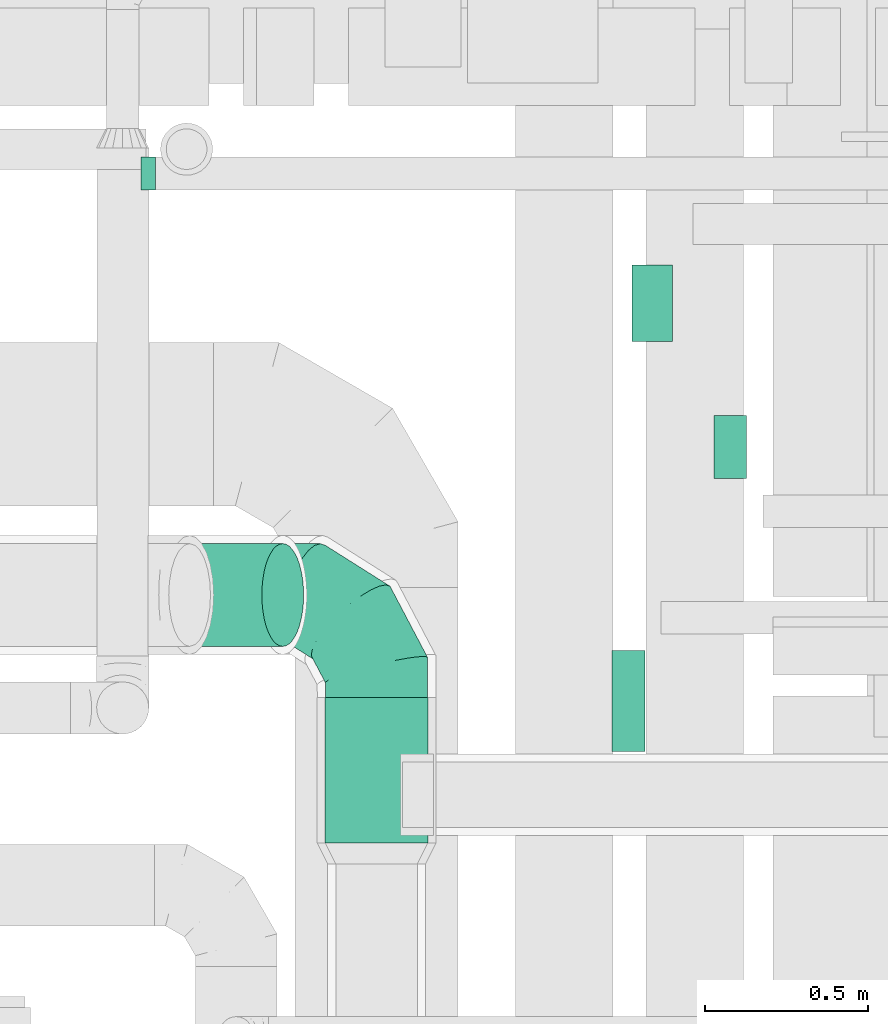
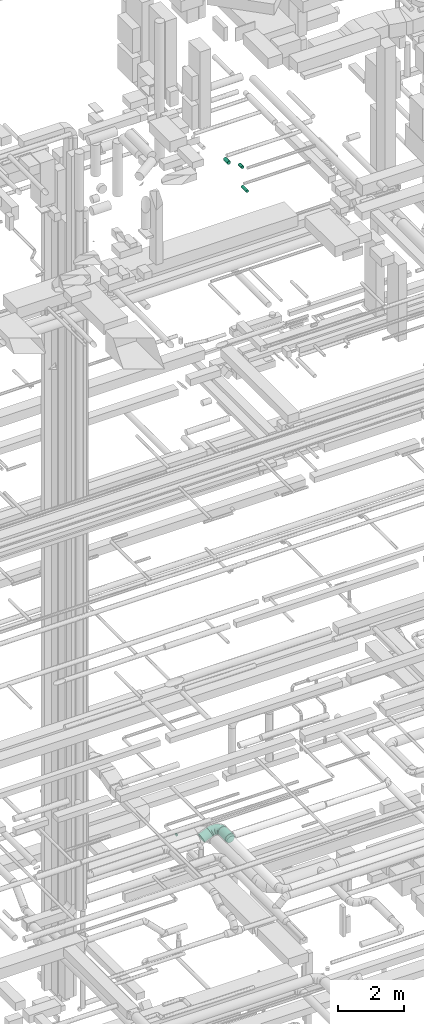
# One storey, part 149 of 337: 5 flow segments, 2 flow fittings.
"""IFC2X3 building model written with IfcOpenShell, lengths in millimetres."""

import ifcopenshell
import ifcopenshell.guid

model = None  # the IFC model being written
_history = None  # IfcOwnerHistory: only IFC2X3 demands one
_inside = {}  # id of a spatial element -> (the spatial element, [elements in it])
_under = {}  # id of a project, library or spatial element -> (it, [spatial elements below it])
_declared = {}  # id of a project -> (the project, [libraries it declares])
_typed = {}  # id of a type object -> (the type object, [elements of that type])
_made_of = {}  # id of a material, layer set ... -> (it, [elements and type objects made of it])


def new_model(schema):
    """Start an empty IFC model of exactly this schema.

    Asked for "IFC4X3", IfcOpenShell would pick the latest addendum, in which some entities
    have other attributes; the version numbers below select the first issue.
    IFC2X3 requires an IfcOwnerHistory on every rooted entity: one is made here for all.
    """
    global model, _history
    if schema == "IFC4X3":
        model = ifcopenshell.file(schema_version=(4, 3, 0, 0))
    else:
        model = ifcopenshell.file(schema=schema)
    _inside.clear()
    _under.clear()
    _declared.clear()
    _typed.clear()
    _made_of.clear()
    _history = None
    if model.schema == "IFC2X3":
        org = make("IfcOrganization", Name="unknown")
        user = make(
            "IfcPersonAndOrganization",
            ThePerson=make("IfcPerson", FamilyName="unknown"),
            TheOrganization=org,
        )
        app = make(
            "IfcApplication",
            ApplicationDeveloper=org,
            Version="unknown",
            ApplicationFullName="unknown",
            ApplicationIdentifier="unknown",
        )
        _history = make(
            "IfcOwnerHistory",
            OwningUser=user,
            OwningApplication=app,
            ChangeAction="ADDED",
            CreationDate=0,
        )
    return model


def make(cls, **values):
    """One entity of the class cls with the attributes given. An attribute that is None is left unset."""
    return model.create_entity(
        cls, **{name: value for name, value in values.items() if value is not None}
    )


def entity(cls, *values):
    """Any entity or typed value of the class cls, its attributes in the order of the schema. None: left unset."""
    e = model.create_entity(cls)
    for i, value in enumerate(values):
        if value is not None:
            e[i] = value
    return e


def rooted(cls, **values):
    """An entity with a GlobalId (a new one), such as an element, a storey or a relation."""
    return make(cls, GlobalId=ifcopenshell.guid.new(), OwnerHistory=_history, **values)


def si_unit(unit_type, name, prefix=None):
    """IfcSIUnit, for example si_unit("LENGTHUNIT", "METRE", prefix="MILLI")."""
    return make("IfcSIUnit", UnitType=unit_type, Prefix=prefix, Name=name)


def converted_unit(unit_type, name, factor, base, dimensions=None, offset=None):
    """IfcConversionBasedUnit, such as the inch: factor (a typed value) times the base unit."""
    return make(
        "IfcConversionBasedUnit"
        if offset is None
        else "IfcConversionBasedUnitWithOffset",
        ConversionOffset=offset,
        Dimensions=None
        if dimensions is None
        else entity("IfcDimensionalExponents", *dimensions),
        UnitType=unit_type,
        Name=name,
        ConversionFactor=make(
            "IfcMeasureWithUnit", ValueComponent=factor, UnitComponent=base
        ),
    )


def derived_unit(unit_type, elements):
    """IfcDerivedUnit: a product of units, each with its exponent."""
    return make(
        "IfcDerivedUnit",
        Elements=[
            make("IfcDerivedUnitElement", Unit=unit, Exponent=power)
            for unit, power in elements
        ],
        UnitType=unit_type,
    )


def assignment(units):
    """IfcUnitAssignment: the units of a project."""
    return None if units is None else make("IfcUnitAssignment", Units=units)


def point(xyz):
    """IfcCartesianPoint."""
    return None if xyz is None else make("IfcCartesianPoint", Coordinates=xyz)


def direction(xyz):
    """IfcDirection."""
    return None if xyz is None else make("IfcDirection", DirectionRatios=xyz)


def frame(location, z_axis=None, x_axis=None):
    """IfcAxis2Placement3D, a coordinate frame: its origin and axes. An axis left out is left unset."""
    return make(
        "IfcAxis2Placement3D",
        Location=point(location),
        Axis=direction(z_axis),
        RefDirection=direction(x_axis),
    )


def frame_2d(location, x_axis=None):
    """IfcAxis2Placement2D, a coordinate frame in the plane: its origin and x axis."""
    return make(
        "IfcAxis2Placement2D", Location=point(location), RefDirection=direction(x_axis)
    )


def origin():
    """The frame at (0, 0, 0) with its axes left unset."""
    return frame((0.0, 0.0, 0.0))


def origin_2d_with_axis():
    """The frame at (0, 0) in the plane with the x axis (1, 0) written out."""
    return frame_2d((0.0, 0.0), x_axis=(1.0, 0.0))


def place(relative_to, where):
    """IfcLocalPlacement: puts the frame where relative to a parent placement (None: the world)."""
    return make(
        "IfcLocalPlacement", PlacementRelTo=relative_to, RelativePlacement=where
    )


def context(
    kind, dimensions, precision=None, world=None, true_north=None, identifier=None
):
    """IfcGeometricRepresentationContext, for example the 3D "Model" context."""
    return make(
        "IfcGeometricRepresentationContext",
        ContextIdentifier=identifier,
        ContextType=kind,
        CoordinateSpaceDimension=dimensions,
        Precision=precision,
        WorldCoordinateSystem=world,
        TrueNorth=true_north,
    )


def subcontext(parent, identifier, kind, view, scale=None):
    """IfcGeometricRepresentationSubContext, for example "Body" below "Model"."""
    return make(
        "IfcGeometricRepresentationSubContext",
        ContextIdentifier=identifier,
        ContextType=kind,
        ParentContext=parent,
        TargetScale=scale,
        TargetView=view,
    )


def project(units=None, contexts=None):
    """IfcProject with its units and contexts."""
    return rooted(
        "IfcProject",
        Name="project",
        RepresentationContexts=contexts,
        UnitsInContext=assignment(units),
    )


def spatial(cls, under=None, at=None, **own):
    """A site, building, storey or space (cls), placed at a placement, below another one or the project."""
    s = rooted(cls, ObjectPlacement=at, **own)
    if under is not None:
        _under.setdefault(under.id(), (under, []))[1].append(s)
    return s


def profile(cls, at=None, kind="AREA", **sizes):
    """A parametric profile (cls). Its sizes go by their IFC names, for example OverallWidth=200.0."""
    return make(cls, ProfileType=kind, Position=at, **sizes)


def circle(**sizes):
    """IfcCircleProfileDef."""
    return profile("IfcCircleProfileDef", **sizes)


def extrude(swept, where, along, depth):
    """IfcExtrudedAreaSolid: the profile swept, set in the frame where, extruded along a direction by depth."""
    return make(
        "IfcExtrudedAreaSolid",
        SweptArea=swept,
        Position=where,
        ExtrudedDirection=direction(along),
        Depth=depth,
    )


def faces_of(points, faces, orient=None, outer=None):
    """IfcFace entities. A face is a list of loops; a loop is a list of indices into points, from 0.

    orient and outer hold one flag for each loop. By default every Orientation is true, the
    first loop of a face is its IfcFaceOuterBound and the others are IfcFaceBound.
    """
    made = []
    for i, loops in enumerate(faces):
        bounds = []
        for j, loop in enumerate(loops):
            is_outer = j == 0 if outer is None else outer[i][j]
            bounds.append(
                make(
                    "IfcFaceOuterBound" if is_outer else "IfcFaceBound",
                    Bound=make("IfcPolyLoop", Polygon=[points[k] for k in loop]),
                    Orientation=True if orient is None else orient[i][j],
                )
            )
        made.append(make("IfcFace", Bounds=bounds))
    return made


def faceted_brep(points, faces, orient=None, outer=None, voids=None):
    """IfcFacetedBrep: a solid bounded by flat faces; with voids (closed shells), ...WithVoids."""
    shared = [point(p) for p in points]
    hull = make("IfcClosedShell", CfsFaces=faces_of(shared, faces, orient, outer))
    if voids is None:
        return make("IfcFacetedBrep", Outer=hull)
    return make(
        "IfcFacetedBrepWithVoids",
        Outer=hull,
        Voids=[
            make(cls, CfsFaces=faces_of(shared, fs, o, b)) for cls, fs, o, b in voids
        ],
    )


def shape(context_of_items, identifier, shape_type, items):
    """IfcShapeRepresentation: the items that make up one representation, for example the "Body"."""
    return make(
        "IfcShapeRepresentation",
        ContextOfItems=context_of_items,
        RepresentationIdentifier=identifier,
        RepresentationType=shape_type,
        Items=items,
    )


def source(mapping_origin, context_of_items, identifier, shape_type, items):
    """IfcRepresentationMap: a shape defined once, which mapped items show again and again."""
    return make(
        "IfcRepresentationMap",
        MappingOrigin=mapping_origin,
        MappedRepresentation=shape(context_of_items, identifier, shape_type, items),
    )


def transform(
    local_origin,
    x_axis=None,
    y_axis=None,
    z_axis=None,
    scale=None,
    scale2=None,
    scale3=None,
    uniform=True,
):
    """IfcCartesianTransformationOperator3D, or its non-uniform kind. x_axis, y_axis, z_axis: its Axis1, 2, 3."""
    if uniform:
        return make(
            "IfcCartesianTransformationOperator3D",
            Axis1=direction(x_axis),
            Axis2=direction(y_axis),
            LocalOrigin=point(local_origin),
            Scale=scale,
            Axis3=direction(z_axis),
        )
    return make(
        "IfcCartesianTransformationOperator3DnonUniform",
        Axis1=direction(x_axis),
        Axis2=direction(y_axis),
        LocalOrigin=point(local_origin),
        Scale=scale,
        Axis3=direction(z_axis),
        Scale2=scale2,
        Scale3=scale3,
    )


def mapped(mapping_source, mapping_target):
    """IfcMappedItem: shows the shape of a source again, moved by a transform."""
    return make(
        "IfcMappedItem", MappingSource=mapping_source, MappingTarget=mapping_target
    )


def material(Name=None, Category=None):
    """IfcMaterial."""
    return make("IfcMaterial", Name=Name, Category=Category)


def made_of(thing, what):
    """Note that an element or type object is made of a material, layer set ...; save() writes the relation."""
    if what is not None:
        _made_of.setdefault(what.id(), (what, []))[1].append(thing)
    return thing


def type_object(cls, material=None, **own):
    """A type object (cls), such as IfcWallType, which elements share."""
    return made_of(rooted(cls, **own), material)


def type_shapes(of_type, sources):
    """Give a type object the sources (RepresentationMaps) that its elements show as mapped items."""
    of_type.RepresentationMaps = sources


def element(
    cls,
    number,
    at=None,
    inside=None,
    cuts=None,
    type_object=None,
    material=None,
    context=None,
    identifier="Body",
    shape_type=None,
    held_by="IfcProductDefinitionShape",
    body=None,
    shapes=None,
    **own,
):
    """One element of the class cls, such as IfcWall. Its Tag is "e" and its number.

    at: its placement. inside: the storey or other place that contains it. cuts: it is an
    opening in that element (IfcRelVoidsElement). A single representation is given by context,
    identifier, shape_type and body (its items); several are given by shapes. held_by: the class
    of the entity that holds the representations. save() writes the other relations.
    """
    e = rooted(cls, Tag="e%d" % number, ObjectPlacement=at, **own)
    if body is not None:
        shapes = [shape(context, identifier, shape_type, body)]
    if shapes is not None:
        e.Representation = make(held_by, Representations=shapes)
    if inside is not None:
        _inside.setdefault(inside.id(), (inside, []))[1].append(e)
    if cuts is not None:
        rooted(
            "IfcRelVoidsElement", RelatingBuildingElement=cuts, RelatedOpeningElement=e
        )
    if type_object is not None:
        _typed.setdefault(type_object.id(), (type_object, []))[1].append(e)
    return made_of(e, material)


def aggregate(whole, parts):
    """IfcRelAggregates: a whole, such as a stair, and the parts it consists of."""
    return rooted("IfcRelAggregates", RelatingObject=whole, RelatedObjects=parts)


def save(model, path):
    """Write the relations noted so far, then the file.

    IfcRelAggregates (storeys below a building ...), IfcRelContainedInSpatialStructure (elements
    in a storey), IfcRelDefinesByType, IfcRelAssociatesMaterial and IfcRelDeclares: one each for
    every whole, place, type object, material and project.
    """
    for whole, parts in _under.values():
        aggregate(whole, parts)
    for where, things in _inside.values():
        rooted(
            "IfcRelContainedInSpatialStructure",
            RelatedElements=things,
            RelatingStructure=where,
        )
    for kind, things in _typed.values():
        rooted("IfcRelDefinesByType", RelatedObjects=things, RelatingType=kind)
    for what, things in _made_of.values():
        rooted("IfcRelAssociatesMaterial", RelatedObjects=things, RelatingMaterial=what)
    for by, libraries in _declared.values():
        rooted("IfcRelDeclares", RelatingContext=by, RelatedDefinitions=libraries)
    model.write(path)


model = new_model("IFC2X3")

# Units and contexts
model_context = context("Model", 3, precision=0.01, world=origin(), true_north=direction((6.12303176911189e-17, 1.0)))
body_context = subcontext(model_context, "Body", "Model", "MODEL_VIEW")
ifc_project = project(units=[si_unit("LENGTHUNIT", "METRE", prefix="MILLI"), si_unit("AREAUNIT", "SQUARE_METRE"), si_unit("VOLUMEUNIT", "CUBIC_METRE"), converted_unit("PLANEANGLEUNIT", "DEGREE", entity("IfcRatioMeasure", 0.0174532925199433), si_unit("PLANEANGLEUNIT", "RADIAN"), dimensions=[0, 0, 0, 0, 0, 0, 0]), si_unit("MASSUNIT", "GRAM", prefix="KILO"), derived_unit("MASSDENSITYUNIT", [(si_unit("MASSUNIT", "GRAM", prefix="KILO"), 1), (si_unit("LENGTHUNIT", "METRE"), -3)]), derived_unit("MOMENTOFINERTIAUNIT", [(si_unit("LENGTHUNIT", "METRE"), 4)]), si_unit("TIMEUNIT", "SECOND"), si_unit("FREQUENCYUNIT", "HERTZ"), si_unit("THERMODYNAMICTEMPERATUREUNIT", "DEGREE_CELSIUS"), derived_unit("THERMALTRANSMITTANCEUNIT", [(si_unit("MASSUNIT", "GRAM", prefix="KILO"), 1), (si_unit("THERMODYNAMICTEMPERATUREUNIT", "KELVIN"), -1), (si_unit("TIMEUNIT", "SECOND"), -3)]), derived_unit("VOLUMETRICFLOWRATEUNIT", [(si_unit("LENGTHUNIT", "METRE"), 3), (si_unit("TIMEUNIT", "SECOND"), -1)]), derived_unit("MASSFLOWRATEUNIT", [(si_unit("MASSUNIT", "GRAM", prefix="KILO"), 1), (si_unit("TIMEUNIT", "SECOND"), -1)]), derived_unit("ROTATIONALFREQUENCYUNIT", [(si_unit("TIMEUNIT", "SECOND"), -1)]), si_unit("ELECTRICCURRENTUNIT", "AMPERE"), si_unit("ELECTRICVOLTAGEUNIT", "VOLT"), si_unit("POWERUNIT", "WATT"), si_unit("FORCEUNIT", "NEWTON", prefix="KILO"), si_unit("ILLUMINANCEUNIT", "LUX"), si_unit("LUMINOUSFLUXUNIT", "LUMEN"), si_unit("LUMINOUSINTENSITYUNIT", "CANDELA"), derived_unit("USERDEFINED", [(si_unit("MASSUNIT", "GRAM", prefix="KILO"), -1), (si_unit("LENGTHUNIT", "METRE"), -2), (si_unit("TIMEUNIT", "SECOND"), 3), (si_unit("LUMINOUSFLUXUNIT", "LUMEN"), 1)]), derived_unit("LINEARVELOCITYUNIT", [(si_unit("LENGTHUNIT", "METRE"), 1), (si_unit("TIMEUNIT", "SECOND"), -1)]), si_unit("PRESSUREUNIT", "PASCAL"), derived_unit("USERDEFINED", [(si_unit("LENGTHUNIT", "METRE"), -2), (si_unit("MASSUNIT", "GRAM", prefix="KILO"), 1), (si_unit("TIMEUNIT", "SECOND"), -2)]), derived_unit("LINEARFORCEUNIT", [(si_unit("MASSUNIT", "GRAM", prefix="KILO"), 1), (si_unit("LENGTHUNIT", "METRE"), 1), (si_unit("TIMEUNIT", "SECOND"), -2), (si_unit("LENGTHUNIT", "METRE"), -1)]), derived_unit("PLANARFORCEUNIT", [(si_unit("MASSUNIT", "GRAM", prefix="KILO"), 1), (si_unit("LENGTHUNIT", "METRE"), 1), (si_unit("TIMEUNIT", "SECOND"), -2), (si_unit("LENGTHUNIT", "METRE"), -2)])], contexts=[model_context])

# Site, building, storey
site_placement = place(None, origin())
site = spatial("IfcSite", under=ifc_project, at=site_placement, CompositionType="ELEMENT")
building_placement = place(site_placement, origin())
building = spatial("IfcBuilding", under=site, at=building_placement, CompositionType="ELEMENT")
storey_placement = place(building_placement, origin())
storey = spatial("IfcBuildingStorey", under=building, at=storey_placement, CompositionType="ELEMENT", Elevation=0.0)

# Flow segments
duct_segment_type = type_object("IfcDuctSegmentType", PredefinedType="NOTDEFINED")
flow_segment_1_placement = place(storey_placement, frame((36585.46, 11764.99, 3423.4)))
element("IfcFlowSegment", 1, at=flow_segment_1_placement, inside=storey, type_object=duct_segment_type, context=body_context, shape_type="SweptSolid", body=[
    extrude(circle(Radius=157.5, at=origin_2d_with_axis()), frame((159.1, 0.0, 159.1), z_axis=(0.0, 1.0, 0.0), x_axis=(-1.0, 0.0, 0.0)), (0.0, 0.0, 1.0), 445.00000000002),
])
flow_segment_2_placement = place(storey_placement, frame((37465.61, 12045.11, 27148.4)))
element("IfcFlowSegment", 2, at=flow_segment_2_placement, inside=storey, type_object=duct_segment_type, context=body_context, shape_type="SweptSolid", body=[
    extrude(circle(Radius=50.0, at=origin_2d_with_axis()), frame((51.6, 0.0, 51.6), z_axis=(0.0, 1.0, 0.0), x_axis=(-1.0, 0.0, 0.0)), (0.0, 0.0, 1.0), 310.000000000025),
])
flow_segment_3_placement = place(storey_placement, frame((37525.93, 13302.52, 27410.9)))
element("IfcFlowSegment", 3, at=flow_segment_3_placement, inside=storey, type_object=duct_segment_type, context=body_context, shape_type="SweptSolid", body=[
    extrude(circle(Radius=62.5, at=origin_2d_with_axis()), frame((64.1, 0.0, 64.1), z_axis=(0.0, 1.0, 0.0), x_axis=(-1.0, 0.0, 0.0)), (0.0, 0.0, 1.0), 234.999336148994),
])
flow_segment_4_placement = place(storey_placement, frame((37777.3, 12881.82, 27423.4)))
element("IfcFlowSegment", 4, at=flow_segment_4_placement, inside=storey, type_object=duct_segment_type, context=body_context, shape_type="SweptSolid", body=[
    extrude(circle(Radius=50.0, at=origin_2d_with_axis()), frame((51.6, 0.0, 51.6), z_axis=(0.0, 1.0, 0.0), x_axis=(1.0, 0.0, 0.0)), (0.0, 0.0, 1.0), 194.375000000006),
])
flow_segment_5_placement = place(storey_placement, frame((36105.56, 12365.89, 3181.75)))
element("IfcFlowSegment", 5, at=flow_segment_5_placement, inside=storey, type_object=duct_segment_type, context=body_context, shape_type="SweptSolid", body=[
    extrude(circle(Radius=157.5, at=origin_2d_with_axis()), frame((65.66, 159.1, 145.48), z_axis=(0.913545457642601, 0.0, 0.406736643075801), x_axis=(0.0, 1.0, 0.0)), (0.0, 0.0, 1.0), 312.597300373771),
])

# Flow fittings
ifc_material = material()
duct_fitting_type_1 = type_object("IfcDuctFittingType", PredefinedType="NOTDEFINED", material=ifc_material)
shared_shape_1 = source(origin(), body_context, "Body", "Brep", [
    faceted_brep([(20.0, 12.94, -48.3), (20.0, 25.0, -43.3), (20.0, 35.36, -35.36), (20.0, 43.3, -25.0), (20.0, 48.3, -12.94), (20.0, 50.0, 0.0), (20.0, 48.3, 12.94), (20.0, 43.3, 25.0), (20.0, 35.36, 35.36), (20.0, 25.0, 43.3), (20.0, 12.94, 48.3), (20.0, 0.0, 50.0), (20.0, -12.94, 48.3), (20.0, -25.0, 43.3), (20.0, -35.36, 35.36), (20.0, -43.3, 25.0), (20.0, -48.3, 12.94), (20.0, -50.0, 0.0), (20.0, -48.3, -12.94), (20.0, -43.3, -25.0), (20.0, -35.36, -35.36), (20.0, -25.0, -43.3), (20.0, -12.94, -48.3), (20.0, 0.0, -50.0), (0.0, 0.0, 50.0), (0.0, 12.94, 48.3), (-23.65, 12.94, 48.3), (-23.65, 0.0, 50.0), (0.0, 25.0, 43.3), (-23.65, 25.0, 43.3), (0.0, 35.36, 35.36), (-23.65, 35.36, 35.36), (0.0, 43.3, 25.0), (0.0, 48.3, 12.94), (-23.65, 48.3, 12.94), (-23.65, 43.3, 25.0), (0.0, 50.0, 0.0), (-23.65, 50.0, 0.0), (0.0, 48.3, -12.94), (-23.65, 48.3, -12.94), (0.0, 43.3, -25.0), (-23.65, 43.3, -25.0), (0.0, 35.36, -35.36), (-23.65, 35.36, -35.36), (0.0, 25.0, -43.3), (0.0, 12.94, -48.3), (-23.65, 12.94, -48.3), (-23.65, 25.0, -43.3), (0.0, 0.0, -50.0), (-23.65, 0.0, -50.0), (0.0, -12.94, -48.3), (-23.65, -12.94, -48.3), (0.0, -25.0, -43.3), (-23.65, -25.0, -43.3), (0.0, -35.36, -35.36), (-23.65, -35.36, -35.36), (0.0, -43.3, -25.0), (0.0, -48.3, -12.94), (-23.65, -48.3, -12.94), (-23.65, -43.3, -25.0), (0.0, -50.0, 0.0), (-23.65, -50.0, 0.0), (0.0, -48.3, 12.94), (-23.65, -48.3, 12.94), (0.0, -43.3, 25.0), (-23.65, -43.3, 25.0), (0.0, -35.36, 35.36), (-23.65, -35.36, 35.36), (0.0, -25.0, 43.3), (0.0, -12.94, 48.3), (-23.65, -12.94, 48.3), (-23.65, -25.0, 43.3)], [[[0, 1, 2, 3, 4, 5, 6, 7, 8, 9, 10, 11, 12, 13, 14, 15, 16, 17, 18, 19, 20, 21, 22, 23]], [[24, 11, 10, 25, 26, 27]], [[25, 10, 9, 28, 29, 26]], [[28, 9, 8, 30, 31, 29]], [[32, 7, 6, 33, 34, 35]], [[33, 6, 5, 36, 37, 34]], [[30, 8, 7, 32, 35, 31]], [[36, 5, 4, 38, 39, 37]], [[38, 4, 3, 40, 41, 39]], [[40, 3, 2, 42, 43, 41]], [[44, 1, 0, 45, 46, 47]], [[45, 0, 23, 48, 49, 46]], [[42, 2, 1, 44, 47, 43]], [[48, 23, 22, 50, 51, 49]], [[50, 22, 21, 52, 53, 51]], [[52, 21, 20, 54, 55, 53]], [[56, 19, 18, 57, 58, 59]], [[57, 18, 17, 60, 61, 58]], [[54, 20, 19, 56, 59, 55]], [[60, 17, 16, 62, 63, 61]], [[62, 16, 15, 64, 65, 63]], [[64, 15, 14, 66, 67, 65]], [[68, 13, 12, 69, 70, 71]], [[69, 12, 11, 24, 27, 70]], [[66, 14, 13, 68, 71, 67]], [[49, 51, 53, 55, 59, 58, 61, 63, 65, 67, 71, 70, 27, 26, 29, 31, 35, 34, 37, 39, 41, 43, 47, 46]]]),
])
type_shapes(duct_fitting_type_1, [shared_shape_1])
flow_fitting_1_placement = place(storey_placement, frame((36046.08, 13817.68, 2720.0), z_axis=(0.0, 0.0, -1.0), x_axis=(1.0, 0.0, 0.0)))
element("IfcFlowFitting", 6, at=flow_fitting_1_placement, inside=storey, type_object=duct_fitting_type_1, material=ifc_material, context=body_context, shape_type="MappedRepresentation", body=[
    mapped(shared_shape_1, transform((0.0, 0.0, 0.0), scale=1.0)),
])
duct_fitting_type_2 = type_object("IfcDuctFittingType", PredefinedType="NOTDEFINED", material=ifc_material)
shared_shape_2 = source(origin(), body_context, "Body", "Brep", [
    faceted_brep([(-315.0, 0.0, -157.5), (-315.0, -40.76, -152.13), (-315.0, -78.75, -136.4), (-315.0, -111.37, -111.37), (-315.0, -136.4, -78.75), (-315.0, -152.13, -40.76), (-315.0, -157.5, 0.0), (-315.0, -152.13, 40.76), (-315.0, -136.4, 78.75), (-315.0, -111.37, 111.37), (-315.0, -78.75, 136.4), (-315.0, -40.76, 152.13), (-315.0, 0.0, 157.5), (-315.0, 40.76, 152.13), (-315.0, 78.75, 136.4), (-315.0, 111.37, 111.37), (-315.0, 136.4, 78.75), (-315.0, 152.13, 40.76), (-315.0, 157.5, 0.0), (-315.0, 152.13, -40.76), (-315.0, 136.4, -78.75), (-315.0, 111.37, -111.37), (-315.0, 78.75, -136.4), (-315.0, 40.76, -152.13), (-241.52, 40.76, 152.13), (-251.7, 78.75, 136.4), (-230.6, 0.0, 157.5), (-260.44, 111.37, 111.37), (-271.36, 152.13, 40.76), (-272.8, 157.5, 0.0), (-267.14, 136.4, 78.75), (-267.14, 136.4, -78.75), (-260.44, 111.37, -111.37), (-271.36, 152.13, -40.76), (-241.52, 40.76, -152.13), (-230.6, 0.0, -157.5), (-251.7, 78.75, -136.4), (-219.67, -40.76, -152.13), (-209.5, -78.75, -136.4), (-200.75, -111.37, -111.37), (-194.05, -136.4, -78.75), (-189.83, -152.13, -40.76), (-188.39, -157.5, 0.0), (-189.83, -152.13, 40.76), (-194.05, -136.4, 78.75), (-200.75, -111.37, 111.37), (-209.5, -78.75, 136.4), (-219.67, -40.76, 152.13), (-114.25, 114.25, 152.13), (-142.05, 142.05, 136.4), (-84.4, 84.4, 157.5), (-165.93, 165.93, 111.37), (-184.25, 184.25, 78.75), (-195.77, 195.77, 40.76), (-199.7, 199.7, 0.0), (-195.77, 195.77, -40.76), (-184.25, 184.25, -78.75), (-165.93, 165.93, -111.37), (-114.25, 114.25, -152.13), (-84.4, 84.4, -157.5), (-142.05, 142.05, -136.4), (-54.56, 54.56, -152.13), (-26.75, 26.75, -136.4), (-2.88, 2.88, -111.37), (15.45, -15.45, -78.75), (26.97, -26.97, -40.76), (30.89, -30.89, 0.0), (26.97, -26.97, 40.76), (15.45, -15.45, 78.75), (-2.88, 2.88, 111.37), (-26.75, 26.75, 136.4), (-54.56, 54.56, 152.13), (-40.76, 241.52, 152.13), (-78.75, 251.7, 136.4), (0.0, 230.6, 157.5), (-111.37, 260.44, 111.37), (-136.4, 267.14, 78.75), (-152.13, 271.36, 40.76), (-157.5, 272.8, 0.0), (-152.13, 271.36, -40.76), (-136.4, 267.14, -78.75), (-111.37, 260.44, -111.37), (-40.76, 241.52, -152.13), (0.0, 230.6, -157.5), (-78.75, 251.7, -136.4), (40.76, 219.67, -152.13), (78.75, 209.5, -136.4), (111.37, 200.75, -111.37), (136.4, 194.05, -78.75), (152.13, 189.83, -40.76), (157.5, 188.39, 0.0), (152.13, 189.83, 40.76), (136.4, 194.05, 78.75), (111.37, 200.75, 111.37), (78.75, 209.5, 136.4), (40.76, 219.67, 152.13), (-40.76, 315.0, -152.13), (-78.75, 315.0, -136.4), (-111.37, 315.0, -111.37), (-136.4, 315.0, -78.75), (-152.13, 315.0, -40.76), (-157.5, 315.0, 0.0), (-152.13, 315.0, 40.76), (-136.4, 315.0, 78.75), (-111.37, 315.0, 111.37), (-78.75, 315.0, 136.4), (-40.76, 315.0, 152.13), (0.0, 315.0, 157.5), (40.76, 315.0, 152.13), (78.75, 315.0, 136.4), (111.37, 315.0, 111.37), (136.4, 315.0, 78.75), (152.13, 315.0, 40.76), (157.5, 315.0, 0.0), (152.13, 315.0, -40.76), (136.4, 315.0, -78.75), (111.37, 315.0, -111.37), (78.75, 315.0, -136.4), (40.76, 315.0, -152.13), (0.0, 315.0, -157.5)], [[[0, 1, 2, 3, 4, 5, 6, 7, 8, 9, 10, 11, 12, 13, 14, 15, 16, 17, 18, 19, 20, 21, 22, 23]], [[24, 25, 14, 13]], [[26, 24, 13, 12]], [[14, 25, 27, 15]], [[28, 29, 18, 17]], [[30, 28, 17, 16]], [[15, 27, 30, 16]], [[20, 31, 32, 21]], [[33, 31, 20, 19]], [[18, 29, 33, 19]], [[34, 35, 0, 23]], [[36, 34, 23, 22]], [[32, 36, 22, 21]], [[1, 0, 35, 37]], [[2, 1, 37, 38]], [[38, 39, 3, 2]], [[5, 4, 40, 41]], [[6, 5, 41, 42]], [[39, 40, 4, 3]], [[6, 42, 43, 7]], [[7, 43, 44, 8]], [[8, 44, 45, 9]], [[9, 45, 46, 10]], [[10, 46, 47, 11]], [[26, 12, 11, 47]], [[48, 49, 25, 24]], [[50, 48, 24, 26]], [[27, 25, 49, 51]], [[52, 53, 28, 30]], [[51, 52, 30, 27]], [[29, 28, 53, 54]], [[55, 56, 31, 33]], [[54, 55, 33, 29]], [[32, 31, 56, 57]], [[58, 59, 35, 34]], [[60, 58, 34, 36]], [[57, 60, 36, 32]], [[37, 35, 59, 61]], [[38, 37, 61, 62]], [[39, 38, 62, 63]], [[41, 40, 64, 65]], [[42, 41, 65, 66]], [[63, 64, 40, 39]], [[43, 42, 66, 67]], [[44, 43, 67, 68]], [[68, 69, 45, 44]], [[46, 45, 69, 70]], [[47, 46, 70, 71]], [[26, 47, 71, 50]], [[72, 73, 49, 48]], [[74, 72, 48, 50]], [[51, 49, 73, 75]], [[76, 77, 53, 52]], [[75, 76, 52, 51]], [[54, 53, 77, 78]], [[79, 80, 56, 55]], [[78, 79, 55, 54]], [[57, 56, 80, 81]], [[82, 83, 59, 58]], [[84, 82, 58, 60]], [[81, 84, 60, 57]], [[61, 59, 83, 85]], [[62, 61, 85, 86]], [[63, 62, 86, 87]], [[65, 64, 88, 89]], [[66, 65, 89, 90]], [[87, 88, 64, 63]], [[67, 66, 90, 91]], [[68, 67, 91, 92]], [[92, 93, 69, 68]], [[70, 69, 93, 94]], [[71, 70, 94, 95]], [[50, 71, 95, 74]], [[96, 97, 98, 99, 100, 101, 102, 103, 104, 105, 106, 107, 108, 109, 110, 111, 112, 113, 114, 115, 116, 117, 118, 119]], [[106, 105, 73, 72]], [[107, 106, 72, 74]], [[75, 73, 105, 104]], [[77, 76, 103, 102]], [[78, 77, 102, 101]], [[104, 103, 76, 75]], [[78, 101, 100, 79]], [[79, 100, 99, 80]], [[98, 81, 80, 99]], [[84, 97, 96, 82]], [[82, 96, 119, 83]], [[97, 84, 81, 98]], [[83, 119, 118, 85]], [[85, 118, 117, 86]], [[116, 87, 86, 117]], [[88, 115, 114, 89]], [[89, 114, 113, 90]], [[115, 88, 87, 116]], [[91, 90, 113, 112]], [[92, 91, 112, 111]], [[111, 110, 93, 92]], [[95, 94, 109, 108]], [[74, 95, 108, 107]], [[110, 109, 94, 93]]]),
])
type_shapes(duct_fitting_type_2, [shared_shape_2])
flow_fitting_2_placement = place(storey_placement, frame((36744.56, 12524.99, 3582.5), z_axis=(-0.406736643075801, 0.0, 0.913545457642601), x_axis=(0.0, 1.0, 0.0)))
element("IfcFlowFitting", 7, at=flow_fitting_2_placement, inside=storey, type_object=duct_fitting_type_2, material=ifc_material, context=body_context, shape_type="MappedRepresentation", body=[
    mapped(shared_shape_2, transform((0.0, 0.0, 0.0), scale=1.0)),
])

save(model, "model.ifc")
